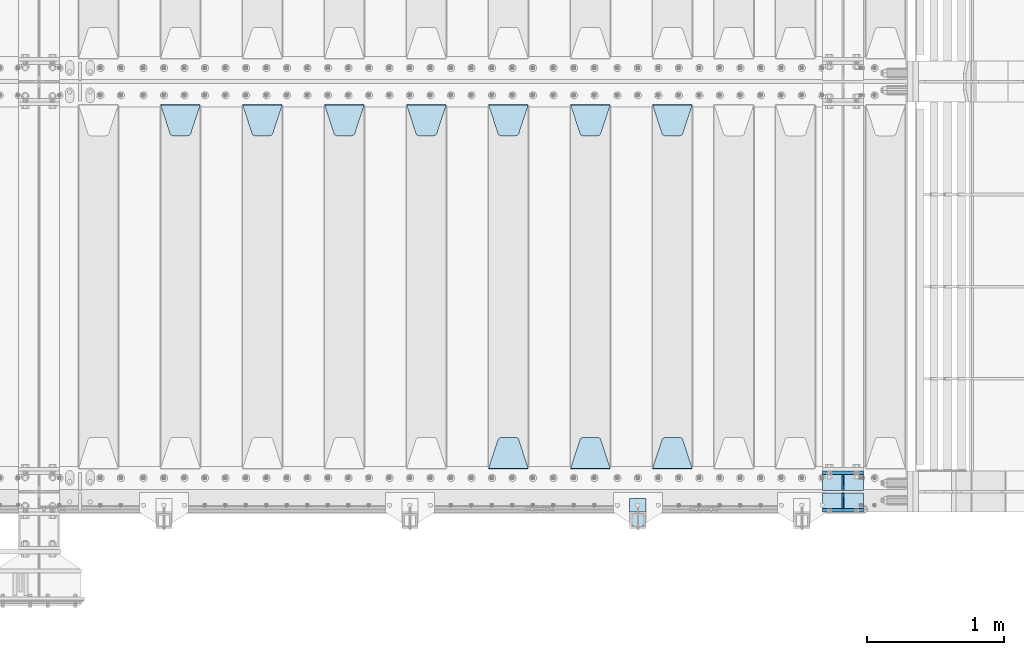
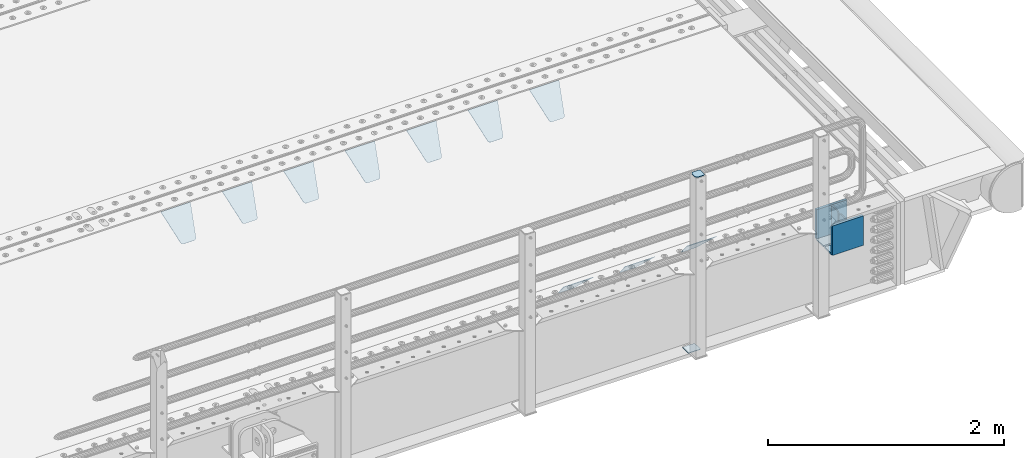
# One storey, part 241 of 270: 18 plates.
"""IFC2X3 building model written with IfcOpenShell, lengths in millimetres."""

import ifcopenshell
import ifcopenshell.guid

model = None  # the IFC model being written
_history = None  # IfcOwnerHistory: only IFC2X3 demands one
_inside = {}  # id of a spatial element -> (the spatial element, [elements in it])
_under = {}  # id of a project, library or spatial element -> (it, [spatial elements below it])
_declared = {}  # id of a project -> (the project, [libraries it declares])
_typed = {}  # id of a type object -> (the type object, [elements of that type])
_made_of = {}  # id of a material, layer set ... -> (it, [elements and type objects made of it])


def new_model(schema):
    """Start an empty IFC model of exactly this schema.

    Asked for "IFC4X3", IfcOpenShell would pick the latest addendum, in which some entities
    have other attributes; the version numbers below select the first issue.
    IFC2X3 requires an IfcOwnerHistory on every rooted entity: one is made here for all.
    """
    global model, _history
    if schema == "IFC4X3":
        model = ifcopenshell.file(schema_version=(4, 3, 0, 0))
    else:
        model = ifcopenshell.file(schema=schema)
    _inside.clear()
    _under.clear()
    _declared.clear()
    _typed.clear()
    _made_of.clear()
    _history = None
    if model.schema == "IFC2X3":
        org = make("IfcOrganization", Name="unknown")
        user = make(
            "IfcPersonAndOrganization",
            ThePerson=make("IfcPerson", FamilyName="unknown"),
            TheOrganization=org,
        )
        app = make(
            "IfcApplication",
            ApplicationDeveloper=org,
            Version="unknown",
            ApplicationFullName="unknown",
            ApplicationIdentifier="unknown",
        )
        _history = make(
            "IfcOwnerHistory",
            OwningUser=user,
            OwningApplication=app,
            ChangeAction="ADDED",
            CreationDate=0,
        )
    return model


def make(cls, **values):
    """One entity of the class cls with the attributes given. An attribute that is None is left unset."""
    return model.create_entity(
        cls, **{name: value for name, value in values.items() if value is not None}
    )


def rooted(cls, **values):
    """An entity with a GlobalId (a new one), such as an element, a storey or a relation."""
    return make(cls, GlobalId=ifcopenshell.guid.new(), OwnerHistory=_history, **values)


def si_unit(unit_type, name, prefix=None):
    """IfcSIUnit, for example si_unit("LENGTHUNIT", "METRE", prefix="MILLI")."""
    return make("IfcSIUnit", UnitType=unit_type, Prefix=prefix, Name=name)


def assignment(units):
    """IfcUnitAssignment: the units of a project."""
    return None if units is None else make("IfcUnitAssignment", Units=units)


def point(xyz):
    """IfcCartesianPoint."""
    return None if xyz is None else make("IfcCartesianPoint", Coordinates=xyz)


def direction(xyz):
    """IfcDirection."""
    return None if xyz is None else make("IfcDirection", DirectionRatios=xyz)


def frame(location, z_axis=None, x_axis=None):
    """IfcAxis2Placement3D, a coordinate frame: its origin and axes. An axis left out is left unset."""
    return make(
        "IfcAxis2Placement3D",
        Location=point(location),
        Axis=direction(z_axis),
        RefDirection=direction(x_axis),
    )


def origin_with_axes():
    """The frame at (0, 0, 0) with the z axis (0, 0, 1) and the x axis (1, 0, 0) written out."""
    return frame((0.0, 0.0, 0.0), z_axis=(0.0, 0.0, 1.0), x_axis=(1.0, 0.0, 0.0))


def place(relative_to, where):
    """IfcLocalPlacement: puts the frame where relative to a parent placement (None: the world)."""
    return make(
        "IfcLocalPlacement", PlacementRelTo=relative_to, RelativePlacement=where
    )


def context(
    kind, dimensions, precision=None, world=None, true_north=None, identifier=None
):
    """IfcGeometricRepresentationContext, for example the 3D "Model" context."""
    return make(
        "IfcGeometricRepresentationContext",
        ContextIdentifier=identifier,
        ContextType=kind,
        CoordinateSpaceDimension=dimensions,
        Precision=precision,
        WorldCoordinateSystem=world,
        TrueNorth=true_north,
    )


def subcontext(parent, identifier, kind, view, scale=None):
    """IfcGeometricRepresentationSubContext, for example "Body" below "Model"."""
    return make(
        "IfcGeometricRepresentationSubContext",
        ContextIdentifier=identifier,
        ContextType=kind,
        ParentContext=parent,
        TargetScale=scale,
        TargetView=view,
    )


def project(units=None, contexts=None):
    """IfcProject with its units and contexts."""
    return rooted(
        "IfcProject",
        Name="project",
        RepresentationContexts=contexts,
        UnitsInContext=assignment(units),
    )


def spatial(cls, under=None, at=None, **own):
    """A site, building, storey or space (cls), placed at a placement, below another one or the project."""
    s = rooted(cls, ObjectPlacement=at, **own)
    if under is not None:
        _under.setdefault(under.id(), (under, []))[1].append(s)
    return s


def faces_of(points, faces, orient=None, outer=None):
    """IfcFace entities. A face is a list of loops; a loop is a list of indices into points, from 0.

    orient and outer hold one flag for each loop. By default every Orientation is true, the
    first loop of a face is its IfcFaceOuterBound and the others are IfcFaceBound.
    """
    made = []
    for i, loops in enumerate(faces):
        bounds = []
        for j, loop in enumerate(loops):
            is_outer = j == 0 if outer is None else outer[i][j]
            bounds.append(
                make(
                    "IfcFaceOuterBound" if is_outer else "IfcFaceBound",
                    Bound=make("IfcPolyLoop", Polygon=[points[k] for k in loop]),
                    Orientation=True if orient is None else orient[i][j],
                )
            )
        made.append(make("IfcFace", Bounds=bounds))
    return made


def faceted_brep(points, faces, orient=None, outer=None, voids=None):
    """IfcFacetedBrep: a solid bounded by flat faces; with voids (closed shells), ...WithVoids."""
    shared = [point(p) for p in points]
    hull = make("IfcClosedShell", CfsFaces=faces_of(shared, faces, orient, outer))
    if voids is None:
        return make("IfcFacetedBrep", Outer=hull)
    return make(
        "IfcFacetedBrepWithVoids",
        Outer=hull,
        Voids=[
            make(cls, CfsFaces=faces_of(shared, fs, o, b)) for cls, fs, o, b in voids
        ],
    )


def shape(context_of_items, identifier, shape_type, items):
    """IfcShapeRepresentation: the items that make up one representation, for example the "Body"."""
    return make(
        "IfcShapeRepresentation",
        ContextOfItems=context_of_items,
        RepresentationIdentifier=identifier,
        RepresentationType=shape_type,
        Items=items,
    )


def material(Name=None, Category=None):
    """IfcMaterial."""
    return make("IfcMaterial", Name=Name, Category=Category)


def made_of(thing, what):
    """Note that an element or type object is made of a material, layer set ...; save() writes the relation."""
    if what is not None:
        _made_of.setdefault(what.id(), (what, []))[1].append(thing)
    return thing


def type_object(cls, material=None, **own):
    """A type object (cls), such as IfcWallType, which elements share."""
    return made_of(rooted(cls, **own), material)


def element(
    cls,
    number,
    at=None,
    inside=None,
    cuts=None,
    type_object=None,
    material=None,
    context=None,
    identifier="Body",
    shape_type=None,
    held_by="IfcProductDefinitionShape",
    body=None,
    shapes=None,
    **own,
):
    """One element of the class cls, such as IfcWall. Its Tag is "e" and its number.

    at: its placement. inside: the storey or other place that contains it. cuts: it is an
    opening in that element (IfcRelVoidsElement). A single representation is given by context,
    identifier, shape_type and body (its items); several are given by shapes. held_by: the class
    of the entity that holds the representations. save() writes the other relations.
    """
    e = rooted(cls, Tag="e%d" % number, ObjectPlacement=at, **own)
    if body is not None:
        shapes = [shape(context, identifier, shape_type, body)]
    if shapes is not None:
        e.Representation = make(held_by, Representations=shapes)
    if inside is not None:
        _inside.setdefault(inside.id(), (inside, []))[1].append(e)
    if cuts is not None:
        rooted(
            "IfcRelVoidsElement", RelatingBuildingElement=cuts, RelatedOpeningElement=e
        )
    if type_object is not None:
        _typed.setdefault(type_object.id(), (type_object, []))[1].append(e)
    return made_of(e, material)


def aggregate(whole, parts):
    """IfcRelAggregates: a whole, such as a stair, and the parts it consists of."""
    return rooted("IfcRelAggregates", RelatingObject=whole, RelatedObjects=parts)


def save(model, path):
    """Write the relations noted so far, then the file.

    IfcRelAggregates (storeys below a building ...), IfcRelContainedInSpatialStructure (elements
    in a storey), IfcRelDefinesByType, IfcRelAssociatesMaterial and IfcRelDeclares: one each for
    every whole, place, type object, material and project.
    """
    for whole, parts in _under.values():
        aggregate(whole, parts)
    for where, things in _inside.values():
        rooted(
            "IfcRelContainedInSpatialStructure",
            RelatedElements=things,
            RelatingStructure=where,
        )
    for kind, things in _typed.values():
        rooted("IfcRelDefinesByType", RelatedObjects=things, RelatingType=kind)
    for what, things in _made_of.values():
        rooted("IfcRelAssociatesMaterial", RelatedObjects=things, RelatingMaterial=what)
    for by, libraries in _declared.values():
        rooted("IfcRelDeclares", RelatingContext=by, RelatedDefinitions=libraries)
    model.write(path)


model = new_model("IFC2X3")

# Units and contexts
model_context = context("Model", 3, precision=1e-05, world=origin_with_axes())
body_context = subcontext(model_context, "Body", "Model", "MODEL_VIEW")
ifc_project = project(units=[si_unit("LENGTHUNIT", "METRE", prefix="MILLI"), si_unit("AREAUNIT", "SQUARE_METRE"), si_unit("VOLUMEUNIT", "CUBIC_METRE"), si_unit("MASSUNIT", "GRAM", prefix="KILO"), si_unit("TIMEUNIT", "SECOND"), si_unit("PLANEANGLEUNIT", "RADIAN"), si_unit("SOLIDANGLEUNIT", "STERADIAN"), si_unit("THERMODYNAMICTEMPERATUREUNIT", "DEGREE_CELSIUS"), si_unit("LUMINOUSINTENSITYUNIT", "LUMEN")], contexts=[model_context])

# Site, building, storey
site_placement = place(None, origin_with_axes())
site = spatial("IfcSite", under=ifc_project, at=site_placement, CompositionType="ELEMENT")
building_placement = place(site_placement, origin_with_axes())
building = spatial("IfcBuilding", under=site, at=building_placement, Name="Standard", CompositionType="ELEMENT")
storey_placement = place(building_placement, origin_with_axes())
storey = spatial("IfcBuildingStorey", under=building, at=storey_placement, Name="Undefined", CompositionType="ELEMENT", Elevation=0.0)

# Plates
ifc_material_1 = material(Name="STEEL/S355N")
plate_type_1 = type_object("IfcPlateType", PredefinedType="NOTDEFINED")
for number, where, z_axis, x_axis in (
    (1, (19768.0, -23862.5, -339.99999999999), (0.0, 0.0, 1.0), (1.0, 0.0, 0.0)),
    (2, (19768.0, -24137.5, -339.99999999999), (0.0, 0.0, 1.0), (1.0, 0.0, 0.0)),
):
    element("IfcPlate", number, at=place(storey_placement, frame(where, z_axis=z_axis, x_axis=x_axis)), inside=storey, type_object=plate_type_1, material=ifc_material_1, context=body_context, shape_type="Brep", body=[
        faceted_brep([(0.0, -12.5, 0.0), (0.0, -12.5, 305.0), (0.0, 12.5, 305.0), (0.0, 12.5, 0.0), (300.0, -12.5, 305.0), (300.0, 12.5, 305.0), (300.0, -12.5, 0.0), (300.0, 12.5, 0.0)], [[[0, 1, 2, 3]], [[1, 4, 5, 2]], [[4, 6, 7, 5]], [[6, 0, 3, 7]], [[5, 7, 3, 2]], [[6, 4, 1, 0]]]),
    ])
plate_type_2 = type_object("IfcPlateType", PredefinedType="NOTDEFINED")
for number, where, z_axis, x_axis in (
    (3, (19768.0, -23990.75, -342.99999999999), (0.0, 1.0, 0.0), (1.0, 0.0, 0.0)),
    (4, (19768.0, -24009.25, -342.99999999999), (0.0, -1.0, 0.0), (1.0, 0.0, 0.0)),
):
    element("IfcPlate", number, at=place(storey_placement, frame(where, z_axis=z_axis, x_axis=x_axis)), inside=storey, type_object=plate_type_2, material=ifc_material_1, context=body_context, shape_type="Brep", body=[
        faceted_brep([(0.0, -7.0, 0.0), (0.0, -7.0, 115.75), (0.0, 7.0, 115.75), (0.0, 7.0, 0.0), (300.0, -7.0, 115.75), (300.0, 7.0, 115.75), (300.0, -7.0, 0.0), (300.0, 7.0, 0.0)], [[[0, 1, 2, 3]], [[1, 4, 5, 2]], [[4, 6, 7, 5]], [[6, 0, 3, 7]], [[5, 7, 3, 2]], [[6, 4, 1, 0]]]),
    ])
plate_type_3 = type_object("IfcPlateType", PredefinedType="NOTDEFINED")
for number, where, z_axis, x_axis in (
    (5, (19918.0, -23990.75, -34.9999999999899), (0.0, 0.0, -1.0), (0.0, 1.0, 0.0)),
    (6, (19918.0, -24009.25, -34.9999999999899), (0.0, 0.0, -1.0), (0.0, -1.0, 0.0)),
):
    element("IfcPlate", number, at=place(storey_placement, frame(where, z_axis=z_axis, x_axis=x_axis)), inside=storey, type_object=plate_type_3, material=ifc_material_1, context=body_context, shape_type="Brep", body=[
        faceted_brep([(0.0, -5.0, 30.0), (0.0, -5.0, 301.0), (0.0, 5.0, 301.0), (0.0, 5.0, 30.0), (115.75, -5.0, 301.0), (115.75, 5.0, 301.0), (115.75, -5.0, 0.0), (115.75, 5.0, 0.0), (30.0, -5.0, 0.0), (30.0, 5.0, 0.0), (24.7905546699913, -5.0, 0.455767409633758), (24.7905546699913, 5.0, 0.455767409633758), (19.7393957002314, -5.0, 1.80922137642275), (19.7393957002314, 5.0, 1.80922137642275), (15.0, -5.0, 4.01923788646684), (15.0, 5.0, 4.01923788646684), (10.7163717094045, -5.0, 7.01866670643066), (10.7163717094045, 5.0, 7.01866670643066), (7.01866670642994, -5.0, 10.7163717094038), (7.01866670642994, 5.0, 10.7163717094038), (4.01923788646673, -5.0, 15.0), (4.01923788646673, 5.0, 15.0), (1.80922137642119, -5.0, 19.7393957002299), (1.80922137642119, 5.0, 19.7393957002299), (0.455767409632244, -5.0, 24.7905546699921), (0.455767409632244, 5.0, 24.7905546699921)], [[[0, 1, 2, 3]], [[1, 4, 5, 2]], [[4, 6, 7, 5]], [[6, 8, 9, 7]], [[8, 10, 11, 9]], [[10, 12, 13, 11]], [[12, 14, 15, 13]], [[14, 16, 17, 15]], [[16, 18, 19, 17]], [[18, 20, 21, 19]], [[20, 22, 23, 21]], [[22, 24, 25, 23]], [[24, 0, 3, 25]], [[5, 7, 9, 11, 13, 15, 17, 19, 21, 23, 25, 3, 2]], [[24, 22, 20, 18, 16, 14, 12, 10, 8, 6, 4, 1, 0]]]),
    ])
ifc_material_2 = material(Name="STEEL/S355J2")
plate_type_4 = type_object("IfcPlateType", PredefinedType="NOTDEFINED")
plate_1_placement = place(storey_placement, frame((18373.9999999999, -24166.0000000002, 1012.50000000001), z_axis=(0.0, -1.0, 0.0), x_axis=(1.0, 0.0, 0.0)))
element("IfcPlate", 7, at=plate_1_placement, inside=storey, type_object=plate_type_4, material=ifc_material_2, context=body_context, shape_type="Brep", body=[
    faceted_brep([(0.0, -2.5, 19.0), (0.0, -2.5, 69.0), (0.0, 2.5, 69.0), (0.0, 2.5, 19.0), (0.476369668544066, -2.5, 73.2278977451697), (0.476369668544066, 2.5, 73.2278977451697), (1.88159150985302, -2.5, 77.2437910432327), (1.88159150985302, 2.5, 77.2437910432327), (4.14520183310742, -2.5, 80.8463062353167), (4.14520183310742, 2.5, 80.8463062353167), (7.15369376468516, -2.5, 83.8547981668926), (7.15369376468516, 2.5, 83.8547981668926), (10.7562089567655, -2.5, 86.1184084901452), (10.7562089567655, 2.5, 86.1184084901452), (14.7721022548285, -2.5, 87.5236303314541), (14.7721022548285, 2.5, 87.5236303314541), (19.0, -2.5, 88.0), (19.0, 2.5, 88.0), (69.0, -2.5, 88.0), (69.0, 2.5, 88.0), (73.2278977451715, -2.5, 87.5236303314541), (73.2278977451715, 2.5, 87.5236303314541), (77.2437910432345, -2.5, 86.1184084901452), (77.2437910432345, 2.5, 86.1184084901452), (80.8463062353148, -2.5, 83.8547981668926), (80.8463062353148, 2.5, 83.8547981668926), (83.8547981668926, -2.5, 80.8463062353167), (83.8547981668926, 2.5, 80.8463062353167), (86.118408490147, -2.5, 77.2437910432345), (86.118408490147, 2.5, 77.2437910432345), (87.5236303314559, -2.5, 73.2278977451697), (87.5236303314559, 2.5, 73.2278977451697), (88.0, -2.5, 69.0), (88.0, 2.5, 69.0), (88.0, -2.5, 19.0), (88.0, 2.5, 19.0), (87.5236303314559, -2.5, 14.7721022548303), (87.5236303314559, 2.5, 14.7721022548303), (86.118408490147, -2.5, 10.7562089567673), (86.118408490147, 2.5, 10.7562089567673), (83.8547981668926, -2.5, 7.15369376468334), (83.8547981668926, 2.5, 7.15369376468334), (80.8463062353148, -2.5, 4.14520183310742), (80.8463062353148, 2.5, 4.14520183310742), (77.2437910432345, -2.5, 1.88159150985484), (77.2437910432345, 2.5, 1.88159150985484), (73.2278977451715, -2.5, 0.476369668545885), (73.2278977451715, 2.5, 0.476369668545885), (69.0, -2.5, 0.0), (69.0, 2.5, 0.0), (19.0, -2.5, 0.0), (19.0, 2.5, 0.0), (14.7721022548285, -2.5, 0.476369668545885), (14.7721022548285, 2.5, 0.476369668545885), (10.7562089567655, -2.5, 1.88159150985484), (10.7562089567655, 2.5, 1.88159150985484), (7.15369376468516, -2.5, 4.14520183310742), (7.15369376468516, 2.5, 4.14520183310742), (4.14520183310742, -2.5, 7.15369376468334), (4.14520183310742, 2.5, 7.15369376468334), (1.88159150985302, -2.5, 10.7562089567673), (1.88159150985302, 2.5, 10.7562089567673), (0.476369668544066, -2.5, 14.7721022548303), (0.476369668544066, 2.5, 14.7721022548303)], [[[0, 1, 2, 3]], [[1, 4, 5, 2]], [[4, 6, 7, 5]], [[6, 8, 9, 7]], [[8, 10, 11, 9]], [[10, 12, 13, 11]], [[12, 14, 15, 13]], [[14, 16, 17, 15]], [[16, 18, 19, 17]], [[18, 20, 21, 19]], [[20, 22, 23, 21]], [[22, 24, 25, 23]], [[24, 26, 27, 25]], [[26, 28, 29, 27]], [[28, 30, 31, 29]], [[30, 32, 33, 31]], [[32, 34, 35, 33]], [[34, 36, 37, 35]], [[36, 38, 39, 37]], [[38, 40, 41, 39]], [[40, 42, 43, 41]], [[42, 44, 45, 43]], [[44, 46, 47, 45]], [[46, 48, 49, 47]], [[48, 50, 51, 49]], [[50, 52, 53, 51]], [[52, 54, 55, 53]], [[54, 56, 57, 55]], [[56, 58, 59, 57]], [[58, 60, 61, 59]], [[60, 62, 63, 61]], [[62, 0, 3, 63]], [[5, 7, 9, 11, 13, 15, 17, 19, 21, 23, 25, 27, 29, 31, 33, 35, 37, 39, 41, 43, 45, 47, 49, 51, 53, 55, 57, 59, 61, 63, 3, 2]], [[62, 60, 58, 56, 54, 52, 50, 48, 46, 44, 42, 40, 38, 36, 34, 32, 30, 28, 26, 24, 22, 20, 18, 16, 14, 12, 10, 8, 6, 4, 1, 0]]]),
])
plate_type_5 = type_object("IfcPlateType", PredefinedType="NOTDEFINED")
plate_2_placement = place(storey_placement, frame((18477.9999999999, -24050.0000000002, -857.500000000002), z_axis=(0.0, -1.0, 0.0), x_axis=(-1.0, 0.0, 0.0)))
element("IfcPlate", 8, at=plate_2_placement, inside=storey, type_object=plate_type_5, material=ifc_material_2, context=body_context, shape_type="Brep", body=[
    faceted_brep([(0.0, -2.5, 0.0), (0.0, -2.5, 100.0), (0.0, 2.5, 100.0), (0.0, 2.5, 0.0), (120.0, -2.5, 100.0), (120.0, 2.5, 100.0), (120.0, -2.5, 0.0), (120.0, 2.5, 0.0)], [[[0, 1, 2, 3]], [[1, 4, 5, 2]], [[4, 6, 7, 5]], [[6, 0, 3, 7]], [[5, 7, 3, 2]], [[6, 4, 1, 0]]]),
])
plate_type_6 = type_object("IfcPlateType", PredefinedType="NOTDEFINED")
plate_3_placement = place(storey_placement, frame((18525.0, -21168.232233044, -1.76776695296576), z_axis=(0.0, -0.707106781186548, -0.707106781186547), x_axis=(1.0, 0.0, 0.0)))
element("IfcPlate", 9, at=plate_3_placement, inside=storey, type_object=plate_type_6, material=ifc_material_1, context=body_context, shape_type="Brep", body=[
    faceted_brep([(0.0, -2.5, 0.0), (69.345504679477, -2.5, 300.171731424831), (69.345504679477, 2.5, 300.171731424831), (0.0, 2.5, 0.0), (70.9274061199576, -2.5, 304.8974424154), (70.9274061199576, 2.5, 304.8974424154), (73.3818627772307, -2.49999999999818, 309.234538108527), (73.3818627772307, 2.50000000000182, 309.234538108527), (76.6187032999551, -2.5, 313.023683126103), (76.6187032999551, 2.5, 313.023683126103), (80.5190132704993, -2.5, 316.125672595372), (80.5190132704993, 2.50000000000182, 316.125672595372), (84.9395038596849, -2.49999999999818, 318.426546230476), (84.9395038596849, 2.5, 318.426546230476), (89.7177759439219, -2.49999999999818, 319.841774983275), (89.7177759439219, 2.50000000000182, 319.841774983275), (94.678286292652, -2.5, 320.319366455078), (94.678286292652, 2.5, 320.319366455078), (195.321713707348, -2.5, 320.319366455078), (195.321713707348, 2.5, 320.319366455078), (200.282224056078, -2.49999999999818, 319.841774983275), (200.282224056078, 2.50000000000182, 319.841774983275), (205.060496140315, -2.5, 318.426546230476), (205.060496140315, 2.5, 318.426546230476), (209.480986729501, -2.5, 316.12567259537), (209.480986729501, 2.50000000000182, 316.12567259537), (213.381296700045, -2.5, 313.023683126103), (213.381296700045, 2.5, 313.023683126103), (216.618137222769, -2.49999999999818, 309.234538108525), (216.618137222769, 2.50000000000182, 309.234538108527), (219.072593880042, -2.49999999999818, 304.897442415398), (219.072593880042, 2.50000000000182, 304.897442415397), (220.654495320523, -2.5, 300.171731424831), (220.654495320523, 2.5, 300.171731424831), (290.0, -2.49999999999818, 0.0), (290.0, 2.5, 0.0)], [[[0, 1, 2, 3]], [[1, 4, 5, 2]], [[4, 6, 7, 5]], [[6, 8, 9, 7]], [[8, 10, 11, 9]], [[10, 12, 13, 11]], [[12, 14, 15, 13]], [[14, 16, 17, 15]], [[16, 18, 19, 17]], [[18, 20, 21, 19]], [[20, 22, 23, 21]], [[22, 24, 25, 23]], [[24, 26, 27, 25]], [[26, 28, 29, 27]], [[28, 30, 31, 29]], [[30, 32, 33, 31]], [[32, 34, 35, 33]], [[34, 0, 3, 35]], [[5, 7, 9, 11, 13, 15, 17, 19, 21, 23, 25, 27, 29, 31, 33, 35, 3, 2]], [[34, 32, 30, 28, 26, 24, 22, 20, 18, 16, 14, 12, 10, 8, 6, 4, 1, 0]]]),
])
plate_4_placement = place(storey_placement, frame((18815.0, -23831.767766953, -1.76776695296758), z_axis=(0.0, 0.707106781186547, -0.707106781186548), x_axis=(-1.0, 0.0, 0.0)))
element("IfcPlate", 10, at=plate_4_placement, inside=storey, type_object=plate_type_6, material=ifc_material_1, context=body_context, shape_type="Brep", body=[
    faceted_brep([(0.0, -2.5, 0.0), (69.345504679477, -2.5, 300.171731424831), (69.345504679477, 2.5, 300.171731424831), (0.0, 2.5, 0.0), (70.9274061199576, -2.5, 304.8974424154), (70.9274061199576, 2.5, 304.8974424154), (73.3818627772307, -2.49999999999818, 309.234538108527), (73.3818627772307, 2.50000000000182, 309.234538108527), (76.6187032999551, -2.5, 313.023683126103), (76.6187032999551, 2.5, 313.023683126103), (80.5190132704993, -2.5, 316.125672595372), (80.5190132704993, 2.50000000000182, 316.125672595372), (84.9395038596849, -2.49999999999818, 318.426546230476), (84.9395038596849, 2.5, 318.426546230476), (89.7177759439219, -2.49999999999818, 319.841774983275), (89.7177759439219, 2.50000000000182, 319.841774983275), (94.678286292652, -2.5, 320.319366455078), (94.678286292652, 2.5, 320.319366455078), (195.321713707348, -2.5, 320.319366455078), (195.321713707348, 2.5, 320.319366455078), (200.282224056078, -2.49999999999818, 319.841774983275), (200.282224056078, 2.50000000000182, 319.841774983275), (205.060496140315, -2.5, 318.426546230476), (205.060496140315, 2.5, 318.426546230476), (209.480986729501, -2.5, 316.12567259537), (209.480986729501, 2.50000000000182, 316.12567259537), (213.381296700045, -2.5, 313.023683126103), (213.381296700045, 2.5, 313.023683126103), (216.618137222769, -2.49999999999818, 309.234538108525), (216.618137222769, 2.50000000000182, 309.234538108527), (219.072593880042, -2.49999999999818, 304.897442415398), (219.072593880042, 2.50000000000182, 304.897442415397), (220.654495320523, -2.5, 300.171731424831), (220.654495320523, 2.5, 300.171731424831), (290.0, -2.49999999999818, 0.0), (290.0, 2.5, 0.0)], [[[0, 1, 2, 3]], [[1, 4, 5, 2]], [[4, 6, 7, 5]], [[6, 8, 9, 7]], [[8, 10, 11, 9]], [[10, 12, 13, 11]], [[12, 14, 15, 13]], [[14, 16, 17, 15]], [[16, 18, 19, 17]], [[18, 20, 21, 19]], [[20, 22, 23, 21]], [[22, 24, 25, 23]], [[24, 26, 27, 25]], [[26, 28, 29, 27]], [[28, 30, 31, 29]], [[30, 32, 33, 31]], [[32, 34, 35, 33]], [[34, 0, 3, 35]], [[5, 7, 9, 11, 13, 15, 17, 19, 21, 23, 25, 27, 29, 31, 33, 35, 3, 2]], [[34, 32, 30, 28, 26, 24, 22, 20, 18, 16, 14, 12, 10, 8, 6, 4, 1, 0]]]),
])
plate_5_placement = place(storey_placement, frame((17925.0, -21168.232233044, -1.76776695296576), z_axis=(0.0, -0.707106781186548, -0.707106781186547), x_axis=(1.0, 0.0, 0.0)))
element("IfcPlate", 11, at=plate_5_placement, inside=storey, type_object=plate_type_6, material=ifc_material_1, context=body_context, shape_type="Brep", body=[
    faceted_brep([(0.0, -2.5, 0.0), (69.345504679477, -2.5, 300.171731424831), (69.345504679477, 2.5, 300.171731424831), (0.0, 2.5, 0.0), (70.9274061199576, -2.5, 304.8974424154), (70.9274061199576, 2.5, 304.8974424154), (73.3818627772307, -2.49999999999818, 309.234538108527), (73.3818627772307, 2.50000000000182, 309.234538108527), (76.6187032999551, -2.5, 313.023683126103), (76.6187032999551, 2.5, 313.023683126103), (80.5190132704993, -2.5, 316.125672595372), (80.5190132704993, 2.50000000000182, 316.125672595372), (84.9395038596849, -2.49999999999818, 318.426546230476), (84.9395038596849, 2.5, 318.426546230476), (89.7177759439219, -2.49999999999818, 319.841774983275), (89.7177759439219, 2.50000000000182, 319.841774983275), (94.678286292652, -2.5, 320.319366455078), (94.678286292652, 2.5, 320.319366455078), (195.321713707348, -2.5, 320.319366455078), (195.321713707348, 2.5, 320.319366455078), (200.282224056078, -2.49999999999818, 319.841774983275), (200.282224056078, 2.50000000000182, 319.841774983275), (205.060496140315, -2.5, 318.426546230476), (205.060496140315, 2.5, 318.426546230476), (209.480986729501, -2.5, 316.12567259537), (209.480986729501, 2.50000000000182, 316.12567259537), (213.381296700045, -2.5, 313.023683126103), (213.381296700045, 2.5, 313.023683126103), (216.618137222769, -2.49999999999818, 309.234538108525), (216.618137222769, 2.50000000000182, 309.234538108527), (219.072593880042, -2.49999999999818, 304.897442415398), (219.072593880042, 2.50000000000182, 304.897442415397), (220.654495320523, -2.5, 300.171731424831), (220.654495320523, 2.5, 300.171731424831), (290.0, -2.49999999999818, 0.0), (290.0, 2.5, 0.0)], [[[0, 1, 2, 3]], [[1, 4, 5, 2]], [[4, 6, 7, 5]], [[6, 8, 9, 7]], [[8, 10, 11, 9]], [[10, 12, 13, 11]], [[12, 14, 15, 13]], [[14, 16, 17, 15]], [[16, 18, 19, 17]], [[18, 20, 21, 19]], [[20, 22, 23, 21]], [[22, 24, 25, 23]], [[24, 26, 27, 25]], [[26, 28, 29, 27]], [[28, 30, 31, 29]], [[30, 32, 33, 31]], [[32, 34, 35, 33]], [[34, 0, 3, 35]], [[5, 7, 9, 11, 13, 15, 17, 19, 21, 23, 25, 27, 29, 31, 33, 35, 3, 2]], [[34, 32, 30, 28, 26, 24, 22, 20, 18, 16, 14, 12, 10, 8, 6, 4, 1, 0]]]),
])
plate_6_placement = place(storey_placement, frame((18215.0, -23831.767766953, -1.76776695296758), z_axis=(0.0, 0.707106781186547, -0.707106781186548), x_axis=(-1.0, 0.0, 0.0)))
element("IfcPlate", 12, at=plate_6_placement, inside=storey, type_object=plate_type_6, material=ifc_material_1, context=body_context, shape_type="Brep", body=[
    faceted_brep([(0.0, -2.5, 0.0), (69.345504679477, -2.5, 300.171731424831), (69.345504679477, 2.5, 300.171731424831), (0.0, 2.5, 0.0), (70.9274061199576, -2.5, 304.8974424154), (70.9274061199576, 2.5, 304.8974424154), (73.3818627772307, -2.49999999999818, 309.234538108527), (73.3818627772307, 2.50000000000182, 309.234538108527), (76.6187032999551, -2.5, 313.023683126103), (76.6187032999551, 2.5, 313.023683126103), (80.5190132704993, -2.5, 316.125672595372), (80.5190132704993, 2.50000000000182, 316.125672595372), (84.9395038596849, -2.49999999999818, 318.426546230476), (84.9395038596849, 2.5, 318.426546230476), (89.7177759439219, -2.49999999999818, 319.841774983275), (89.7177759439219, 2.50000000000182, 319.841774983275), (94.678286292652, -2.5, 320.319366455078), (94.678286292652, 2.5, 320.319366455078), (195.321713707348, -2.5, 320.319366455078), (195.321713707348, 2.5, 320.319366455078), (200.282224056078, -2.49999999999818, 319.841774983275), (200.282224056078, 2.50000000000182, 319.841774983275), (205.060496140315, -2.5, 318.426546230476), (205.060496140315, 2.5, 318.426546230476), (209.480986729501, -2.5, 316.12567259537), (209.480986729501, 2.50000000000182, 316.12567259537), (213.381296700045, -2.5, 313.023683126103), (213.381296700045, 2.5, 313.023683126103), (216.618137222769, -2.49999999999818, 309.234538108525), (216.618137222769, 2.50000000000182, 309.234538108527), (219.072593880042, -2.49999999999818, 304.897442415398), (219.072593880042, 2.50000000000182, 304.897442415397), (220.654495320523, -2.5, 300.171731424831), (220.654495320523, 2.5, 300.171731424831), (290.0, -2.49999999999818, 0.0), (290.0, 2.5, 0.0)], [[[0, 1, 2, 3]], [[1, 4, 5, 2]], [[4, 6, 7, 5]], [[6, 8, 9, 7]], [[8, 10, 11, 9]], [[10, 12, 13, 11]], [[12, 14, 15, 13]], [[14, 16, 17, 15]], [[16, 18, 19, 17]], [[18, 20, 21, 19]], [[20, 22, 23, 21]], [[22, 24, 25, 23]], [[24, 26, 27, 25]], [[26, 28, 29, 27]], [[28, 30, 31, 29]], [[30, 32, 33, 31]], [[32, 34, 35, 33]], [[34, 0, 3, 35]], [[5, 7, 9, 11, 13, 15, 17, 19, 21, 23, 25, 27, 29, 31, 33, 35, 3, 2]], [[34, 32, 30, 28, 26, 24, 22, 20, 18, 16, 14, 12, 10, 8, 6, 4, 1, 0]]]),
])
plate_7_placement = place(storey_placement, frame((17325.0, -21168.232233044, -1.76776695296576), z_axis=(0.0, -0.707106781186548, -0.707106781186547), x_axis=(1.0, 0.0, 0.0)))
element("IfcPlate", 13, at=plate_7_placement, inside=storey, type_object=plate_type_6, material=ifc_material_1, context=body_context, shape_type="Brep", body=[
    faceted_brep([(0.0, -2.5, 0.0), (69.345504679477, -2.5, 300.171731424831), (69.345504679477, 2.5, 300.171731424831), (0.0, 2.5, 0.0), (70.9274061199576, -2.5, 304.8974424154), (70.9274061199576, 2.5, 304.8974424154), (73.3818627772307, -2.49999999999818, 309.234538108527), (73.3818627772307, 2.50000000000182, 309.234538108527), (76.6187032999551, -2.5, 313.023683126103), (76.6187032999551, 2.5, 313.023683126103), (80.5190132704993, -2.5, 316.125672595372), (80.5190132704993, 2.50000000000182, 316.125672595372), (84.9395038596849, -2.49999999999818, 318.426546230476), (84.9395038596849, 2.5, 318.426546230476), (89.7177759439219, -2.49999999999818, 319.841774983275), (89.7177759439219, 2.50000000000182, 319.841774983275), (94.678286292652, -2.5, 320.319366455078), (94.678286292652, 2.5, 320.319366455078), (195.321713707348, -2.5, 320.319366455078), (195.321713707348, 2.5, 320.319366455078), (200.282224056078, -2.49999999999818, 319.841774983275), (200.282224056078, 2.50000000000182, 319.841774983275), (205.060496140315, -2.5, 318.426546230476), (205.060496140315, 2.5, 318.426546230476), (209.480986729501, -2.5, 316.12567259537), (209.480986729501, 2.50000000000182, 316.12567259537), (213.381296700045, -2.5, 313.023683126103), (213.381296700045, 2.5, 313.023683126103), (216.618137222769, -2.49999999999818, 309.234538108525), (216.618137222769, 2.50000000000182, 309.234538108527), (219.072593880042, -2.49999999999818, 304.897442415398), (219.072593880042, 2.50000000000182, 304.897442415397), (220.654495320523, -2.5, 300.171731424831), (220.654495320523, 2.5, 300.171731424831), (290.0, -2.49999999999818, 0.0), (290.0, 2.5, 0.0)], [[[0, 1, 2, 3]], [[1, 4, 5, 2]], [[4, 6, 7, 5]], [[6, 8, 9, 7]], [[8, 10, 11, 9]], [[10, 12, 13, 11]], [[12, 14, 15, 13]], [[14, 16, 17, 15]], [[16, 18, 19, 17]], [[18, 20, 21, 19]], [[20, 22, 23, 21]], [[22, 24, 25, 23]], [[24, 26, 27, 25]], [[26, 28, 29, 27]], [[28, 30, 31, 29]], [[30, 32, 33, 31]], [[32, 34, 35, 33]], [[34, 0, 3, 35]], [[5, 7, 9, 11, 13, 15, 17, 19, 21, 23, 25, 27, 29, 31, 33, 35, 3, 2]], [[34, 32, 30, 28, 26, 24, 22, 20, 18, 16, 14, 12, 10, 8, 6, 4, 1, 0]]]),
])
plate_8_placement = place(storey_placement, frame((17615.0, -23831.767766953, -1.76776695296758), z_axis=(0.0, 0.707106781186547, -0.707106781186548), x_axis=(-1.0, 0.0, 0.0)))
element("IfcPlate", 14, at=plate_8_placement, inside=storey, type_object=plate_type_6, material=ifc_material_1, context=body_context, shape_type="Brep", body=[
    faceted_brep([(0.0, -2.5, 0.0), (69.345504679477, -2.5, 300.171731424831), (69.345504679477, 2.5, 300.171731424831), (0.0, 2.5, 0.0), (70.9274061199576, -2.5, 304.8974424154), (70.9274061199576, 2.5, 304.8974424154), (73.3818627772307, -2.49999999999818, 309.234538108527), (73.3818627772307, 2.50000000000182, 309.234538108527), (76.6187032999551, -2.5, 313.023683126103), (76.6187032999551, 2.5, 313.023683126103), (80.5190132704993, -2.5, 316.125672595372), (80.5190132704993, 2.50000000000182, 316.125672595372), (84.9395038596849, -2.49999999999818, 318.426546230476), (84.9395038596849, 2.5, 318.426546230476), (89.7177759439219, -2.49999999999818, 319.841774983275), (89.7177759439219, 2.50000000000182, 319.841774983275), (94.678286292652, -2.5, 320.319366455078), (94.678286292652, 2.5, 320.319366455078), (195.321713707348, -2.5, 320.319366455078), (195.321713707348, 2.5, 320.319366455078), (200.282224056078, -2.49999999999818, 319.841774983275), (200.282224056078, 2.50000000000182, 319.841774983275), (205.060496140315, -2.5, 318.426546230476), (205.060496140315, 2.5, 318.426546230476), (209.480986729501, -2.5, 316.12567259537), (209.480986729501, 2.50000000000182, 316.12567259537), (213.381296700045, -2.5, 313.023683126103), (213.381296700045, 2.5, 313.023683126103), (216.618137222769, -2.49999999999818, 309.234538108525), (216.618137222769, 2.50000000000182, 309.234538108527), (219.072593880042, -2.49999999999818, 304.897442415398), (219.072593880042, 2.50000000000182, 304.897442415397), (220.654495320523, -2.5, 300.171731424831), (220.654495320523, 2.5, 300.171731424831), (290.0, -2.49999999999818, 0.0), (290.0, 2.5, 0.0)], [[[0, 1, 2, 3]], [[1, 4, 5, 2]], [[4, 6, 7, 5]], [[6, 8, 9, 7]], [[8, 10, 11, 9]], [[10, 12, 13, 11]], [[12, 14, 15, 13]], [[14, 16, 17, 15]], [[16, 18, 19, 17]], [[18, 20, 21, 19]], [[20, 22, 23, 21]], [[22, 24, 25, 23]], [[24, 26, 27, 25]], [[26, 28, 29, 27]], [[28, 30, 31, 29]], [[30, 32, 33, 31]], [[32, 34, 35, 33]], [[34, 0, 3, 35]], [[5, 7, 9, 11, 13, 15, 17, 19, 21, 23, 25, 27, 29, 31, 33, 35, 3, 2]], [[34, 32, 30, 28, 26, 24, 22, 20, 18, 16, 14, 12, 10, 8, 6, 4, 1, 0]]]),
])
plate_9_placement = place(storey_placement, frame((16725.0, -21168.232233044, -1.76776695296576), z_axis=(0.0, -0.707106781186548, -0.707106781186547), x_axis=(1.0, 0.0, 0.0)))
element("IfcPlate", 15, at=plate_9_placement, inside=storey, type_object=plate_type_6, material=ifc_material_1, context=body_context, shape_type="Brep", body=[
    faceted_brep([(0.0, -2.5, 0.0), (69.345504679477, -2.5, 300.171731424831), (69.345504679477, 2.5, 300.171731424831), (0.0, 2.5, 0.0), (70.9274061199576, -2.5, 304.8974424154), (70.9274061199576, 2.5, 304.8974424154), (73.3818627772307, -2.49999999999818, 309.234538108527), (73.3818627772307, 2.50000000000182, 309.234538108527), (76.6187032999551, -2.5, 313.023683126103), (76.6187032999551, 2.5, 313.023683126103), (80.5190132704993, -2.5, 316.125672595372), (80.5190132704993, 2.50000000000182, 316.125672595372), (84.9395038596849, -2.49999999999818, 318.426546230476), (84.9395038596849, 2.5, 318.426546230476), (89.7177759439219, -2.49999999999818, 319.841774983275), (89.7177759439219, 2.50000000000182, 319.841774983275), (94.678286292652, -2.5, 320.319366455078), (94.678286292652, 2.5, 320.319366455078), (195.321713707348, -2.5, 320.319366455078), (195.321713707348, 2.5, 320.319366455078), (200.282224056078, -2.49999999999818, 319.841774983275), (200.282224056078, 2.50000000000182, 319.841774983275), (205.060496140315, -2.5, 318.426546230476), (205.060496140315, 2.5, 318.426546230476), (209.480986729501, -2.5, 316.12567259537), (209.480986729501, 2.50000000000182, 316.12567259537), (213.381296700045, -2.5, 313.023683126103), (213.381296700045, 2.5, 313.023683126103), (216.618137222769, -2.49999999999818, 309.234538108525), (216.618137222769, 2.50000000000182, 309.234538108527), (219.072593880042, -2.49999999999818, 304.897442415398), (219.072593880042, 2.50000000000182, 304.897442415397), (220.654495320523, -2.5, 300.171731424831), (220.654495320523, 2.5, 300.171731424831), (290.0, -2.49999999999818, 0.0), (290.0, 2.5, 0.0)], [[[0, 1, 2, 3]], [[1, 4, 5, 2]], [[4, 6, 7, 5]], [[6, 8, 9, 7]], [[8, 10, 11, 9]], [[10, 12, 13, 11]], [[12, 14, 15, 13]], [[14, 16, 17, 15]], [[16, 18, 19, 17]], [[18, 20, 21, 19]], [[20, 22, 23, 21]], [[22, 24, 25, 23]], [[24, 26, 27, 25]], [[26, 28, 29, 27]], [[28, 30, 31, 29]], [[30, 32, 33, 31]], [[32, 34, 35, 33]], [[34, 0, 3, 35]], [[5, 7, 9, 11, 13, 15, 17, 19, 21, 23, 25, 27, 29, 31, 33, 35, 3, 2]], [[34, 32, 30, 28, 26, 24, 22, 20, 18, 16, 14, 12, 10, 8, 6, 4, 1, 0]]]),
])
plate_10_placement = place(storey_placement, frame((16125.0, -21168.232233044, -1.76776695296576), z_axis=(0.0, -0.707106781186548, -0.707106781186547), x_axis=(1.0, 0.0, 0.0)))
element("IfcPlate", 16, at=plate_10_placement, inside=storey, type_object=plate_type_6, material=ifc_material_1, context=body_context, shape_type="Brep", body=[
    faceted_brep([(0.0, -2.5, 0.0), (69.345504679477, -2.5, 300.171731424831), (69.345504679477, 2.5, 300.171731424831), (0.0, 2.5, 0.0), (70.9274061199576, -2.5, 304.8974424154), (70.9274061199576, 2.5, 304.8974424154), (73.3818627772307, -2.49999999999818, 309.234538108527), (73.3818627772307, 2.50000000000182, 309.234538108527), (76.6187032999551, -2.5, 313.023683126103), (76.6187032999551, 2.5, 313.023683126103), (80.5190132704993, -2.5, 316.125672595372), (80.5190132704993, 2.50000000000182, 316.125672595372), (84.9395038596849, -2.49999999999818, 318.426546230476), (84.9395038596849, 2.5, 318.426546230476), (89.7177759439219, -2.49999999999818, 319.841774983275), (89.7177759439219, 2.50000000000182, 319.841774983275), (94.678286292652, -2.5, 320.319366455078), (94.678286292652, 2.5, 320.319366455078), (195.321713707348, -2.5, 320.319366455078), (195.321713707348, 2.5, 320.319366455078), (200.282224056078, -2.49999999999818, 319.841774983275), (200.282224056078, 2.50000000000182, 319.841774983275), (205.060496140315, -2.5, 318.426546230476), (205.060496140315, 2.5, 318.426546230476), (209.480986729501, -2.5, 316.12567259537), (209.480986729501, 2.50000000000182, 316.12567259537), (213.381296700045, -2.5, 313.023683126103), (213.381296700045, 2.5, 313.023683126103), (216.618137222769, -2.49999999999818, 309.234538108525), (216.618137222769, 2.50000000000182, 309.234538108527), (219.072593880042, -2.49999999999818, 304.897442415398), (219.072593880042, 2.50000000000182, 304.897442415397), (220.654495320523, -2.5, 300.171731424831), (220.654495320523, 2.5, 300.171731424831), (290.0, -2.49999999999818, 0.0), (290.0, 2.5, 0.0)], [[[0, 1, 2, 3]], [[1, 4, 5, 2]], [[4, 6, 7, 5]], [[6, 8, 9, 7]], [[8, 10, 11, 9]], [[10, 12, 13, 11]], [[12, 14, 15, 13]], [[14, 16, 17, 15]], [[16, 18, 19, 17]], [[18, 20, 21, 19]], [[20, 22, 23, 21]], [[22, 24, 25, 23]], [[24, 26, 27, 25]], [[26, 28, 29, 27]], [[28, 30, 31, 29]], [[30, 32, 33, 31]], [[32, 34, 35, 33]], [[34, 0, 3, 35]], [[5, 7, 9, 11, 13, 15, 17, 19, 21, 23, 25, 27, 29, 31, 33, 35, 3, 2]], [[34, 32, 30, 28, 26, 24, 22, 20, 18, 16, 14, 12, 10, 8, 6, 4, 1, 0]]]),
])
plate_11_placement = place(storey_placement, frame((15525.0, -21168.232233044, -1.76776695296576), z_axis=(0.0, -0.707106781186548, -0.707106781186547), x_axis=(1.0, 0.0, 0.0)))
element("IfcPlate", 17, at=plate_11_placement, inside=storey, type_object=plate_type_6, material=ifc_material_1, context=body_context, shape_type="Brep", body=[
    faceted_brep([(0.0, -2.5, 0.0), (69.345504679477, -2.5, 300.171731424831), (69.345504679477, 2.5, 300.171731424831), (0.0, 2.5, 0.0), (70.9274061199576, -2.5, 304.8974424154), (70.9274061199576, 2.5, 304.8974424154), (73.3818627772307, -2.49999999999818, 309.234538108527), (73.3818627772307, 2.50000000000182, 309.234538108527), (76.6187032999551, -2.5, 313.023683126103), (76.6187032999551, 2.5, 313.023683126103), (80.5190132704993, -2.5, 316.125672595372), (80.5190132704993, 2.50000000000182, 316.125672595372), (84.9395038596849, -2.49999999999818, 318.426546230476), (84.9395038596849, 2.5, 318.426546230476), (89.7177759439219, -2.49999999999818, 319.841774983275), (89.7177759439219, 2.50000000000182, 319.841774983275), (94.678286292652, -2.5, 320.319366455078), (94.678286292652, 2.5, 320.319366455078), (195.321713707348, -2.5, 320.319366455078), (195.321713707348, 2.5, 320.319366455078), (200.282224056078, -2.49999999999818, 319.841774983275), (200.282224056078, 2.50000000000182, 319.841774983275), (205.060496140315, -2.5, 318.426546230476), (205.060496140315, 2.5, 318.426546230476), (209.480986729501, -2.5, 316.12567259537), (209.480986729501, 2.50000000000182, 316.12567259537), (213.381296700045, -2.5, 313.023683126103), (213.381296700045, 2.5, 313.023683126103), (216.618137222769, -2.49999999999818, 309.234538108525), (216.618137222769, 2.50000000000182, 309.234538108527), (219.072593880042, -2.49999999999818, 304.897442415398), (219.072593880042, 2.50000000000182, 304.897442415397), (220.654495320523, -2.5, 300.171731424831), (220.654495320523, 2.5, 300.171731424831), (290.0, -2.49999999999818, 0.0), (290.0, 2.5, 0.0)], [[[0, 1, 2, 3]], [[1, 4, 5, 2]], [[4, 6, 7, 5]], [[6, 8, 9, 7]], [[8, 10, 11, 9]], [[10, 12, 13, 11]], [[12, 14, 15, 13]], [[14, 16, 17, 15]], [[16, 18, 19, 17]], [[18, 20, 21, 19]], [[20, 22, 23, 21]], [[22, 24, 25, 23]], [[24, 26, 27, 25]], [[26, 28, 29, 27]], [[28, 30, 31, 29]], [[30, 32, 33, 31]], [[32, 34, 35, 33]], [[34, 0, 3, 35]], [[5, 7, 9, 11, 13, 15, 17, 19, 21, 23, 25, 27, 29, 31, 33, 35, 3, 2]], [[34, 32, 30, 28, 26, 24, 22, 20, 18, 16, 14, 12, 10, 8, 6, 4, 1, 0]]]),
])
plate_12_placement = place(storey_placement, frame((14925.0, -21168.232233044, -1.76776695296576), z_axis=(0.0, -0.707106781186548, -0.707106781186547), x_axis=(1.0, 0.0, 0.0)))
element("IfcPlate", 18, at=plate_12_placement, inside=storey, type_object=plate_type_6, material=ifc_material_1, context=body_context, shape_type="Brep", body=[
    faceted_brep([(0.0, -2.5, 0.0), (69.345504679477, -2.5, 300.171731424831), (69.345504679477, 2.5, 300.171731424831), (0.0, 2.5, 0.0), (70.9274061199576, -2.5, 304.8974424154), (70.9274061199576, 2.5, 304.8974424154), (73.3818627772307, -2.49999999999818, 309.234538108527), (73.3818627772307, 2.50000000000182, 309.234538108527), (76.6187032999551, -2.5, 313.023683126103), (76.6187032999551, 2.5, 313.023683126103), (80.5190132704993, -2.5, 316.125672595372), (80.5190132704993, 2.50000000000182, 316.125672595372), (84.9395038596849, -2.49999999999818, 318.426546230476), (84.9395038596849, 2.5, 318.426546230476), (89.7177759439219, -2.49999999999818, 319.841774983275), (89.7177759439219, 2.50000000000182, 319.841774983275), (94.678286292652, -2.5, 320.319366455078), (94.678286292652, 2.5, 320.319366455078), (195.321713707348, -2.5, 320.319366455078), (195.321713707348, 2.5, 320.319366455078), (200.282224056078, -2.49999999999818, 319.841774983275), (200.282224056078, 2.50000000000182, 319.841774983275), (205.060496140315, -2.5, 318.426546230476), (205.060496140315, 2.5, 318.426546230476), (209.480986729501, -2.5, 316.12567259537), (209.480986729501, 2.50000000000182, 316.12567259537), (213.381296700045, -2.5, 313.023683126103), (213.381296700045, 2.5, 313.023683126103), (216.618137222769, -2.49999999999818, 309.234538108525), (216.618137222769, 2.50000000000182, 309.234538108527), (219.072593880042, -2.49999999999818, 304.897442415398), (219.072593880042, 2.50000000000182, 304.897442415397), (220.654495320523, -2.5, 300.171731424831), (220.654495320523, 2.5, 300.171731424831), (290.0, -2.49999999999818, 0.0), (290.0, 2.5, 0.0)], [[[0, 1, 2, 3]], [[1, 4, 5, 2]], [[4, 6, 7, 5]], [[6, 8, 9, 7]], [[8, 10, 11, 9]], [[10, 12, 13, 11]], [[12, 14, 15, 13]], [[14, 16, 17, 15]], [[16, 18, 19, 17]], [[18, 20, 21, 19]], [[20, 22, 23, 21]], [[22, 24, 25, 23]], [[24, 26, 27, 25]], [[26, 28, 29, 27]], [[28, 30, 31, 29]], [[30, 32, 33, 31]], [[32, 34, 35, 33]], [[34, 0, 3, 35]], [[5, 7, 9, 11, 13, 15, 17, 19, 21, 23, 25, 27, 29, 31, 33, 35, 3, 2]], [[34, 32, 30, 28, 26, 24, 22, 20, 18, 16, 14, 12, 10, 8, 6, 4, 1, 0]]]),
])

save(model, "model.ifc")
